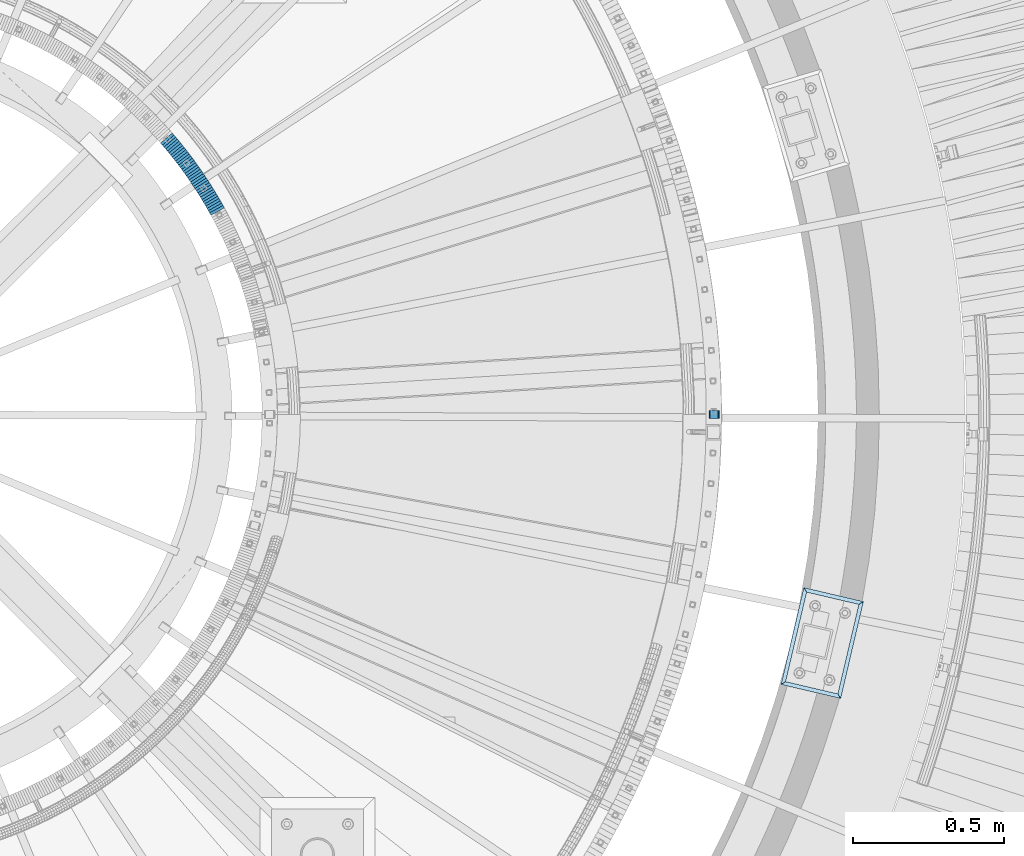
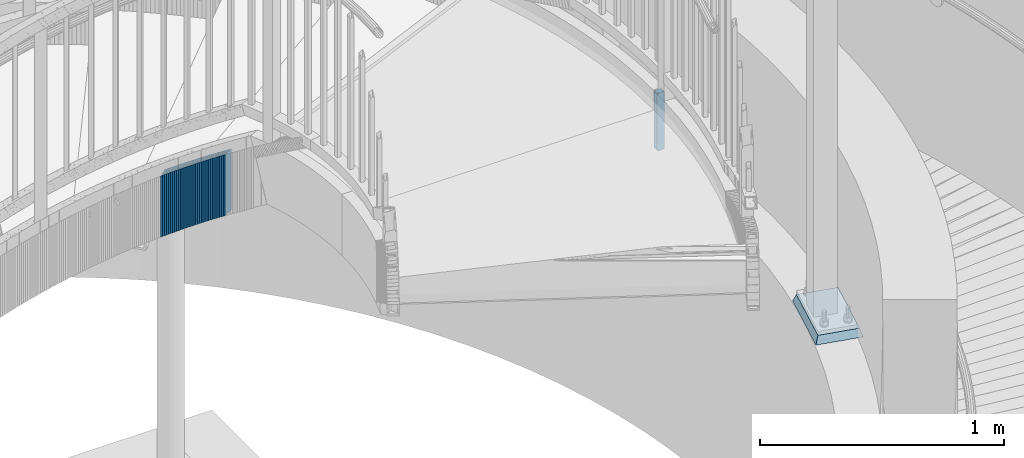
# One storey, part 910 of 975: 36 plates.
"""IFC2X3 building model written with IfcOpenShell, lengths in millimetres."""

from ifc_helpers import new_model, si_unit, frame, origin_with_axes, place, context, subcontext, project, spatial, faceted_brep, material, type_object, element, save


model = new_model("IFC2X3")

# Units and contexts
model_context = context("Model", 3, precision=1e-05, world=origin_with_axes())
body_context = subcontext(model_context, "Body", "Model", "MODEL_VIEW")
ifc_project = project(units=[si_unit("LENGTHUNIT", "METRE", prefix="MILLI"), si_unit("AREAUNIT", "SQUARE_METRE"), si_unit("VOLUMEUNIT", "CUBIC_METRE"), si_unit("MASSUNIT", "GRAM", prefix="KILO"), si_unit("TIMEUNIT", "SECOND"), si_unit("PLANEANGLEUNIT", "RADIAN"), si_unit("SOLIDANGLEUNIT", "STERADIAN"), si_unit("THERMODYNAMICTEMPERATUREUNIT", "DEGREE_CELSIUS"), si_unit("LUMINOUSINTENSITYUNIT", "LUMEN")], contexts=[model_context])

# Site, building, storey
site_placement = place(None, origin_with_axes())
site = spatial("IfcSite", under=ifc_project, at=site_placement, CompositionType="ELEMENT")
building_placement = place(site_placement, origin_with_axes())
building = spatial("IfcBuilding", under=site, at=building_placement, Name="Undefined", CompositionType="ELEMENT")
storey_placement = place(building_placement, origin_with_axes())
storey = spatial("IfcBuildingStorey", under=building, at=storey_placement, Name="Undefined", CompositionType="ELEMENT", Elevation=0.0)

# Plates
ifc_material_1 = material(Name="STEEL/A36")
plate_type_1 = type_object("IfcPlateType", PredefinedType="NOTDEFINED")
plate_1_placement = place(storey_placement, frame((37622.9779779098, 3403.59999999999, 2176.46249923706), z_axis=(0.0, 0.0, -1.0), x_axis=(-0.999999999999998, 6.90000001668524e-08, 0.0)))
element("IfcPlate", 1, at=plate_1_placement, inside=storey, type_object=plate_type_1, material=ifc_material_1, Name="PLATE", context=body_context, shape_type="Brep", body=[
    faceted_brep([(-4.05850369133987e-06, -12.7000000000298, 6.34999584616526), (0.0, -12.6999999999998, 282.574987888336), (0.0, 12.6999999999998, 282.574987888336), (-4.05842729378492e-06, 12.7000000000335, 6.34999584617253), (0.483364961291954, -12.6999999999998, 285.005027647359), (0.483364961291954, 12.6999999999998, 285.005027647359), (1.85987191153254, -12.6999999999998, 287.065115881436), (1.85987191153254, 12.6999999999998, 287.065115881436), (3.919960145613, -12.6999999999998, 288.441622831675), (3.919960145613, 12.6999999999998, 288.441622831675), (6.34999990463257, -12.6999999999998, 288.924987792969), (6.34999990463257, 12.6999999999998, 288.924987792969), (28.5687317848206, -12.6999999999998, 288.924987792969), (28.5687317848206, 12.6999999999998, 288.924987792969), (30.9987715438401, -12.6999999999998, 288.441622831675), (30.9987715438401, 12.6999999999998, 288.441622831675), (33.0588597779206, -12.6999999999998, 287.065115881436), (33.0588597779206, 12.6999999999998, 287.065115881436), (34.4353667281612, -12.6999999999998, 285.005027647359), (34.4353667281612, 12.6999999999998, 285.005027647359), (34.9187316894531, -12.6999999999998, 282.574987888336), (34.9187316894531, 12.6999999999998, 282.574987888336), (34.9187276514203, -12.6999999999643, 6.35000394271628), (34.9187276514895, 12.7000000000917, 6.35000394272356), (34.4353638491048, -12.6999999999607, 3.91996294363889), (34.4353638491739, 12.7000000000917, 3.91996294364617), (33.0588597779206, -12.6999999999998, 1.85987191153299), (33.0588597779206, 12.6999999999998, 1.85987191153299), (30.9987715438401, -12.6999999999998, 0.483364961293773), (30.9987715438401, 12.6999999999998, 0.483364961293773), (28.5687317848206, -12.6999999999998, 0.0), (28.5687317848206, 12.6999999999998, 0.0), (6.34999990463257, -12.6999999999998, 0.0), (6.34999990463257, 12.6999999999998, 0.0), (3.919960145613, -12.6999999999998, 0.483364961293773), (3.919960145613, 12.6999999999998, 0.483364961293773), (1.85987191153254, -12.6999999999998, 1.85987191153299), (1.85987191153254, 12.6999999999998, 1.85987191153299), (0.483362067625421, -12.7000000000262, 3.91995733345902), (0.483362067694543, 12.7000000000298, 3.91995733346448)], [[[0, 1, 2, 3]], [[1, 4, 5, 2]], [[4, 6, 7, 5]], [[6, 8, 9, 7]], [[8, 10, 11, 9]], [[10, 12, 13, 11]], [[12, 14, 15, 13]], [[14, 16, 17, 15]], [[16, 18, 19, 17]], [[18, 20, 21, 19]], [[20, 22, 23, 21]], [[22, 24, 25, 23]], [[24, 26, 27, 25]], [[26, 28, 29, 27]], [[28, 30, 31, 29]], [[30, 32, 33, 31]], [[32, 34, 35, 33]], [[34, 36, 37, 35]], [[36, 38, 39, 37]], [[38, 0, 3, 39]], [[5, 7, 9, 11, 13, 15, 17, 19, 21, 23, 25, 27, 29, 31, 33, 35, 37, 39, 3, 2]], [[38, 36, 34, 32, 30, 28, 26, 24, 22, 20, 18, 16, 14, 12, 10, 8, 6, 4, 1, 0]]]),
])
plate_type_2 = type_object("IfcPlateType", PredefinedType="NOTDEFINED")
plate_2_placement = place(storey_placement, frame((35954.131730669, 4084.69492811208, 2035.5000000012), z_axis=(0.482780508932904, -0.875741388878295, 0.0), x_axis=(0.0, 0.0, -1.0)))
element("IfcPlate", 2, at=plate_2_placement, inside=storey, type_object=plate_type_2, material=ifc_material_1, Name="WALL", context=body_context, shape_type="Brep", body=[
    faceted_brep([(0.0, -25.3999999999724, -1.81898940354586e-11), (-5.69999980926514, -25.400000000096, 8.9140338897214), (-5.69999980926514, 25.4000000000524, 8.91403388979779), (0.0, 25.3999999999869, 1.45519152283669e-11), (299.100006103516, -25.400000000096, 8.9140338897214), (299.100006103516, 25.4000000000524, 8.91403388979779), (304.799987792969, -25.3999999999724, -1.81898940354586e-11), (304.799987792969, 25.3999999999869, 1.45519152283669e-11)], [[[0, 1, 2, 3]], [[1, 4, 5, 2]], [[4, 6, 7, 5]], [[6, 0, 3, 7]], [[5, 7, 3, 2]], [[6, 4, 1, 0]]]),
])
plate_3_placement = place(storey_placement, frame((35949.8527088723, 4092.27799489274, 2029.8000000012), z_axis=(0.491321186669782, -0.870978467890795, 1.51524091052124e-10), x_axis=(0.0, 0.0, -1.0)))
element("IfcPlate", 3, at=plate_3_placement, inside=storey, type_object=plate_type_2, material=ifc_material_1, Name="WALL", context=body_context, shape_type="Brep", body=[
    faceted_brep([(0.0, -25.3999999999724, -1.81898940354586e-11), (-5.69999980926514, -25.4000000000087, 8.9643735885511), (-5.69999980926514, 25.4000000000669, 8.96437358860567), (0.0, 25.3999999999869, 1.45519152283669e-11), (299.100006103516, -25.4000000000087, 8.9643735885511), (299.100006103516, 25.4000000000669, 8.96437358860567), (304.799987792969, -25.3999999999724, -1.81898940354586e-11), (304.799987792969, 25.3999999999869, 1.45519152283669e-11)], [[[0, 1, 2, 3]], [[1, 4, 5, 2]], [[4, 6, 7, 5]], [[6, 0, 3, 7]], [[5, 7, 3, 2]], [[6, 4, 1, 0]]]),
])
for number, where, z_axis, x_axis, name in (
    (4, (35945.5221861386, 4099.8556240108, 2024.10000000119), (0.496138938141448, -0.868243142247537, 0.0), (0.0, 0.0, -1.0), "WALL"),
    (5, (35941.1221861366, 4107.5556240109, 2018.40000000118), (0.496138938141448, -0.868243142247537, 0.0), (0.0, 0.0, -1.0), "WALL"),
):
    element("IfcPlate", number, at=place(storey_placement, frame(where, z_axis=z_axis, x_axis=x_axis)), inside=storey, type_object=plate_type_2, material=ifc_material_1, Name=name, context=body_context, shape_type="Brep", body=[
        faceted_brep([(0.0, -25.3999999999724, -1.81898940354586e-11), (-5.69999980926514, -25.4000000000378, 8.86848354337781), (-5.69999980926514, 25.4000000000451, 8.86848354342146), (0.0, 25.3999999999869, 1.45519152283669e-11), (299.100006103516, -25.4000000000378, 8.86848354337781), (299.100006103516, 25.4000000000451, 8.86848354342146), (304.799987792969, -25.3999999999724, -1.81898940354586e-11), (304.799987792969, 25.3999999999869, 1.45519152283669e-11)], [[[0, 1, 2, 3]], [[1, 4, 5, 2]], [[4, 6, 7, 5]], [[6, 0, 3, 7]], [[5, 7, 3, 2]], [[6, 4, 1, 0]]]),
    ])
plate_4_placement = place(storey_placement, frame((35936.7459145663, 4115.04152535319, 2012.70000000118), z_axis=(0.504568019426507, -0.863371944049615, -2.19346475205384e-10), x_axis=(0.0, 0.0, -1.0)))
element("IfcPlate", 6, at=plate_4_placement, inside=storey, type_object=plate_type_2, material=ifc_material_1, Name="WALL", context=body_context, shape_type="Brep", body=[
    faceted_brep([(0.0, -25.3999999999724, -1.81898940354586e-11), (-5.69999980926514, -25.3999999999724, 8.91964149478372), (-5.69999980926514, 25.400000000016, 8.9196414947528), (0.0, 25.3999999999869, 1.45519152283669e-11), (299.100006103516, -25.3999999999724, 8.91964149478372), (299.100006103516, 25.400000000016, 8.9196414947528), (304.799987792969, -25.3999999999724, -1.81898940354586e-11), (304.799987792969, 25.3999999999869, 1.45519152283669e-11)], [[[0, 1, 2, 3]], [[1, 4, 5, 2]], [[4, 6, 7, 5]], [[6, 0, 3, 7]], [[5, 7, 3, 2]], [[6, 4, 1, 0]]]),
])
plate_5_placement = place(storey_placement, frame((35932.3194870752, 4122.51645606271, 2007.00000000118), z_axis=(0.509492006930814, -0.860475388883152, 0.0), x_axis=(0.0, 0.0, -1.0)))
element("IfcPlate", 7, at=plate_5_placement, inside=storey, type_object=plate_type_2, material=ifc_material_1, Name="WALL", context=body_context, shape_type="Brep", body=[
    faceted_brep([(0.0, -25.3999999999724, -1.81898940354586e-11), (-5.69999980926514, -25.4000000000742, 8.8323268889817), (-5.69999980926514, 25.4000000000815, 8.83232688909084), (0.0, 25.3999999999869, 1.45519152283669e-11), (299.100006103516, -25.4000000000742, 8.8323268889817), (299.100006103516, 25.4000000000815, 8.83232688909084), (304.799987792969, -25.3999999999724, -1.81898940354586e-11), (304.799987792969, 25.3999999999869, 1.45519152283669e-11)], [[[0, 1, 2, 3]], [[1, 4, 5, 2]], [[4, 6, 7, 5]], [[6, 0, 3, 7]], [[5, 7, 3, 2]], [[6, 4, 1, 0]]]),
])
plate_6_placement = place(storey_placement, frame((35927.7702945126, 4130.13102963732, 2001.30000000117), z_axis=(0.51285525212439, -0.858475095951204, -8.52323864819481e-11), x_axis=(0.0, 0.0, -1.0)))
element("IfcPlate", 8, at=plate_6_placement, inside=storey, type_object=plate_type_2, material=ifc_material_1, Name="WALL", context=body_context, shape_type="Brep", body=[
    faceted_brep([(0.0, -25.3999999999724, -1.81898940354586e-11), (-5.69999980926514, -25.4000000000669, 8.96939277644015), (-5.69999980926514, 25.4000000000524, 8.96939277652928), (0.0, 25.3999999999869, 1.45519152283669e-11), (299.100006103516, -25.4000000000669, 8.96939277644015), (299.100006103516, 25.4000000000524, 8.96939277652928), (304.799987792969, -25.3999999999724, -1.81898940354586e-11), (304.799987792969, 25.3999999999869, 1.45519152283669e-11)], [[[0, 1, 2, 3]], [[1, 4, 5, 2]], [[4, 6, 7, 5]], [[6, 0, 3, 7]], [[5, 7, 3, 2]], [[6, 4, 1, 0]]]),
])
plate_7_placement = place(storey_placement, frame((35923.3525425906, 4137.16979423657, 1995.60000000116), z_axis=(0.531014126038609, -0.847362967061609, 0.0), x_axis=(0.0, 0.0, -1.0)))
element("IfcPlate", 9, at=plate_7_placement, inside=storey, type_object=plate_type_2, material=ifc_material_1, Name="WALL", context=body_context, shape_type="Brep", body=[
    faceted_brep([(0.0, -25.3999999999724, -1.81898940354586e-11), (-5.69999980926514, -25.4000000000669, 8.85494232174278), (-5.69999980926514, 25.4000000000742, 8.85494232181918), (0.0, 25.3999999999869, 1.45519152283669e-11), (299.100006103516, -25.4000000000669, 8.85494232174278), (299.100006103516, 25.4000000000742, 8.85494232181918), (304.799987792969, -25.3999999999724, -1.81898940354586e-11), (304.799987792969, 25.3999999999869, 1.45519152283669e-11)], [[[0, 1, 2, 3]], [[1, 4, 5, 2]], [[4, 6, 7, 5]], [[6, 0, 3, 7]], [[5, 7, 3, 2]], [[6, 4, 1, 0]]]),
])
plate_8_placement = place(storey_placement, frame((35918.5458599453, 4145.10536498801, 1989.90000000115), z_axis=(0.517802678981105, -0.855500079275268, 1.01825207821094e-10), x_axis=(0.0, 0.0, -1.0)))
element("IfcPlate", 10, at=plate_8_placement, inside=storey, type_object=plate_type_2, material=ifc_material_1, Name="WALL", context=body_context, shape_type="Brep", body=[
    faceted_brep([(0.0, -25.3999999999724, -1.81898940354586e-11), (-5.69999980926514, -25.4000000000669, 8.8814411163039), (-5.69999980926514, 25.400000000096, 8.88144111637848), (0.0, 25.3999999999869, 1.45519152283669e-11), (299.100006103516, -25.4000000000669, 8.8814411163039), (299.100006103516, 25.400000000096, 8.88144111637848), (304.799987792969, -25.3999999999724, -1.81898940354586e-11), (304.799987792969, 25.3999999999869, 1.45519152283669e-11)], [[[0, 1, 2, 3]], [[1, 4, 5, 2]], [[4, 6, 7, 5]], [[6, 0, 3, 7]], [[5, 7, 3, 2]], [[6, 4, 1, 0]]]),
])
plate_9_placement = place(storey_placement, frame((35914.0818683767, 4152.06558915964, 1984.20000000114), z_axis=(0.539053696363117, -0.842271400700072, -2.99270595860435e-10), x_axis=(0.0, 0.0, -1.0)))
element("IfcPlate", 11, at=plate_9_placement, inside=storey, type_object=plate_type_2, material=ifc_material_1, Name="WALL", context=body_context, shape_type="Brep", body=[
    faceted_brep([(0.0, -25.3999999999724, -1.81898940354586e-11), (-5.69999980926514, -25.3999999999724, 8.90224647524519), (-5.69999980926514, 25.3999999999542, 8.90224647519426), (0.0, 25.3999999999869, 1.45519152283669e-11), (299.100006103516, -25.3999999999724, 8.90224647524519), (299.100006103516, 25.3999999999542, 8.90224647519426), (304.799987792969, -25.3999999999724, -1.81898940354586e-11), (304.799987792969, 25.3999999999869, 1.45519152283669e-11)], [[[0, 1, 2, 3]], [[1, 4, 5, 2]], [[4, 6, 7, 5]], [[6, 0, 3, 7]], [[5, 7, 3, 2]], [[6, 4, 1, 0]]]),
])
plate_10_placement = place(storey_placement, frame((35909.3346378059, 4159.53966878909, 1978.50000000114), z_axis=(0.536137175139273, -0.844130872219279, 0.0), x_axis=(0.0, 0.0, -1.0)))
element("IfcPlate", 12, at=plate_10_placement, inside=storey, type_object=plate_type_2, material=ifc_material_1, Name="WALL", context=body_context, shape_type="Brep", body=[
    faceted_brep([(0.0, -25.3999999999724, -1.81898940354586e-11), (-5.69999980926514, -25.399999999936, 8.76641273502901), (-5.69999980926514, 25.4000000000015, 8.76641273496898), (0.0, 25.3999999999869, 1.45519152283669e-11), (299.100006103516, -25.399999999936, 8.76641273502901), (299.100006103516, 25.4000000000015, 8.76641273496898), (304.799987792969, -25.3999999999724, -1.81898940354586e-11), (304.799987792969, 25.3999999999869, 1.45519152283669e-11)], [[[0, 1, 2, 3]], [[1, 4, 5, 2]], [[4, 6, 7, 5]], [[6, 0, 3, 7]], [[5, 7, 3, 2]], [[6, 4, 1, 0]]]),
])
plate_11_placement = place(storey_placement, frame((35904.5818683802, 4166.96558915965, 1972.80000000113), z_axis=(0.539053696363117, -0.842271400700072, -2.99270595860435e-10), x_axis=(0.0, 0.0, -1.0)))
element("IfcPlate", 13, at=plate_11_placement, inside=storey, type_object=plate_type_2, material=ifc_material_1, Name="WALL", context=body_context, shape_type="Brep", body=[
    faceted_brep([(0.0, -25.3999999999724, -1.81898940354586e-11), (-5.69999980926514, -25.3999999999724, 8.90224647524519), (-5.69999980926514, 25.3999999999542, 8.90224647519426), (0.0, 25.3999999999869, 1.45519152283669e-11), (299.100006103516, -25.3999999999724, 8.90224647524519), (299.100006103516, 25.3999999999542, 8.90224647519426), (304.799987792969, -25.3999999999724, -1.81898940354586e-11), (304.799987792969, 25.3999999999869, 1.45519152283669e-11)], [[[0, 1, 2, 3]], [[1, 4, 5, 2]], [[4, 6, 7, 5]], [[6, 0, 3, 7]], [[5, 7, 3, 2]], [[6, 4, 1, 0]]]),
])
plate_12_placement = place(storey_placement, frame((35899.8975585646, 4174.03428052, 1967.10000000112), z_axis=(0.552097343096909, -0.833779661388627, 8.59072315506636e-11), x_axis=(0.0, 0.0, -1.0)))
element("IfcPlate", 14, at=plate_12_placement, inside=storey, type_object=plate_type_2, material=ifc_material_1, Name="WALL", context=body_context, shape_type="Brep", body=[
    faceted_brep([(0.0, -25.3999999999724, -1.81898940354586e-11), (-5.69999980926514, -25.4000000000669, 8.8814411163039), (-5.69999980926514, 25.400000000096, 8.88144111637848), (0.0, 25.3999999999869, 1.45519152283669e-11), (299.100006103516, -25.4000000000669, 8.8814411163039), (299.100006103516, 25.400000000096, 8.88144111637848), (304.799987792969, -25.3999999999724, -1.81898940354586e-11), (304.799987792969, 25.3999999999869, 1.45519152283669e-11)], [[[0, 1, 2, 3]], [[1, 4, 5, 2]], [[4, 6, 7, 5]], [[6, 0, 3, 7]], [[5, 7, 3, 2]], [[6, 4, 1, 0]]]),
])
plate_13_placement = place(storey_placement, frame((35894.9975585624, 4181.43428052024, 1961.50000000111), z_axis=(0.552097343096909, -0.833779661388627, 8.59072315506636e-11), x_axis=(0.0, 0.0, -1.0)))
element("IfcPlate", 15, at=plate_13_placement, inside=storey, type_object=plate_type_2, material=ifc_material_1, Name="WALL", context=body_context, shape_type="Brep", body=[
    faceted_brep([(0.0, -25.3999999999724, -1.81898940354586e-11), (-5.59999990463257, -25.3999999999614, 8.87524604800456), (-5.59999990463257, 25.3999999999323, 8.87524604792998), (0.0, 25.3999999999869, 1.45519152283669e-11), (299.200012207031, -25.3999999999614, 8.87524604800456), (299.200012207031, 25.3999999999323, 8.87524604792998), (304.799987792969, -25.3999999999724, -1.81898940354586e-11), (304.799987792969, 25.3999999999869, 1.45519152283669e-11)], [[[0, 1, 2, 3]], [[1, 4, 5, 2]], [[4, 6, 7, 5]], [[6, 0, 3, 7]], [[5, 7, 3, 2]], [[6, 4, 1, 0]]]),
])
plate_14_placement = place(storey_placement, frame((35890.1860354407, 4188.60156946435, 1955.80000000111), z_axis=(0.557322187932383, -0.830296319899265, 0.0), x_axis=(0.0, 0.0, -1.0)))
element("IfcPlate", 16, at=plate_14_placement, inside=storey, type_object=plate_type_2, material=ifc_material_1, Name="WALL", context=body_context, shape_type="Brep", body=[
    faceted_brep([(0.0, -25.3999999999724, -1.81898940354586e-11), (-5.69999980926514, -25.4000000000669, 8.79204177851716), (-5.69999980926514, 25.4000000000487, 8.79204177860811), (0.0, 25.3999999999869, 1.45519152283669e-11), (299.100006103516, -25.4000000000669, 8.79204177851716), (299.100006103516, 25.4000000000487, 8.79204177860811), (304.799987792969, -25.3999999999724, -1.81898940354586e-11), (304.799987792969, 25.3999999999869, 1.45519152283669e-11)], [[[0, 1, 2, 3]], [[1, 4, 5, 2]], [[4, 6, 7, 5]], [[6, 0, 3, 7]], [[5, 7, 3, 2]], [[6, 4, 1, 0]]]),
])
plate_15_placement = place(storey_placement, frame((35885.2294021584, 4195.93717479967, 1950.1000000011), z_axis=(0.559857411630225, -0.828588968453421, -5.37864252692088e-10), x_axis=(0.0, 0.0, -1.0)))
element("IfcPlate", 17, at=plate_15_placement, inside=storey, type_object=plate_type_2, material=ifc_material_1, Name="WALL", context=body_context, shape_type="Brep", body=[
    faceted_brep([(0.0, -25.3999999999724, -1.81898940354586e-11), (-5.69999980926514, -25.3999999999141, 8.92748546604707), (-5.69999980926514, 25.3999999999505, 8.92748546598159), (0.0, 25.3999999999869, 1.45519152283669e-11), (299.100006103516, -25.3999999999141, 8.92748546604707), (299.100006103516, 25.3999999999505, 8.92748546598159), (304.799987792969, -25.3999999999724, -1.81898940354586e-11), (304.799987792969, 25.3999999999869, 1.45519152283669e-11)], [[[0, 1, 2, 3]], [[1, 4, 5, 2]], [[4, 6, 7, 5]], [[6, 0, 3, 7]], [[5, 7, 3, 2]], [[6, 4, 1, 0]]]),
])
plate_16_placement = place(storey_placement, frame((35880.2614034806, 4203.14374110295, 1944.30000000109), z_axis=(0.567472910754157, -0.823392066733828, 3.25858309224714e-11), x_axis=(0.0, 0.0, -1.0)))
element("IfcPlate", 18, at=plate_16_placement, inside=storey, type_object=plate_type_2, material=ifc_material_1, Name="WALL", context=body_context, shape_type="Brep", body=[
    faceted_brep([(0.0, -25.3999999999724, -1.81898940354586e-11), (-5.80000019073486, -25.3999999999796, 8.98721313478018), (-5.80000019073486, 25.399999999936, 8.98721313473106), (0.0, 25.3999999999869, 1.45519152283669e-11), (299.0, -25.3999999999796, 8.98721313478018), (299.0, 25.399999999936, 8.98721313473106), (304.799987792969, -25.3999999999724, -1.81898940354586e-11), (304.799987792969, 25.3999999999869, 1.45519152283669e-11)], [[[0, 1, 2, 3]], [[1, 4, 5, 2]], [[4, 6, 7, 5]], [[6, 0, 3, 7]], [[5, 7, 3, 2]], [[6, 4, 1, 0]]]),
])
plate_17_placement = place(storey_placement, frame((35875.2876007686, 4210.12092312949, 1938.60000000107), z_axis=(0.580182279890535, -0.814486661708478, -5.08648554387038e-11), x_axis=(0.0, 0.0, -1.0)))
element("IfcPlate", 19, at=plate_17_placement, inside=storey, type_object=plate_type_2, material=ifc_material_1, Name="WALL", context=body_context, shape_type="Brep", body=[
    faceted_brep([(0.0, -25.3999999999724, -1.81898940354586e-11), (-5.69999980926514, -25.4000000000087, 8.9643735885511), (-5.69999980926514, 25.4000000000669, 8.96437358860567), (0.0, 25.3999999999869, 1.45519152283669e-11), (299.100006103516, -25.4000000000087, 8.9643735885511), (299.100006103516, 25.4000000000669, 8.96437358860567), (304.799987792969, -25.3999999999724, -1.81898940354586e-11), (304.799987792969, 25.3999999999869, 1.45519152283669e-11)], [[[0, 1, 2, 3]], [[1, 4, 5, 2]], [[4, 6, 7, 5]], [[6, 0, 3, 7]], [[5, 7, 3, 2]], [[6, 4, 1, 0]]]),
])
plate_18_placement = place(storey_placement, frame((35870.0876007709, 4217.42092312917, 1932.80000000106), z_axis=(0.580182279890535, -0.814486661708478, -5.08648554387038e-11), x_axis=(0.0, 0.0, -1.0)))
element("IfcPlate", 20, at=plate_18_placement, inside=storey, type_object=plate_type_2, material=ifc_material_1, Name="WALL", context=body_context, shape_type="Brep", body=[
    faceted_brep([(0.0, -25.3999999999724, -1.81898940354586e-11), (-5.80000019073486, -25.3999999999396, 8.9627008438656), (-5.80000019073486, 25.3999999999178, 8.96270084374191), (0.0, 25.3999999999869, 1.45519152283669e-11), (299.0, -25.3999999999396, 8.9627008438656), (299.0, 25.3999999999178, 8.96270084374191), (304.799987792969, -25.3999999999724, -1.81898940354586e-11), (304.799987792969, 25.3999999999869, 1.45519152283669e-11)], [[[0, 1, 2, 3]], [[1, 4, 5, 2]], [[4, 6, 7, 5]], [[6, 0, 3, 7]], [[5, 7, 3, 2]], [[6, 4, 1, 0]]]),
])
plate_19_placement = place(storey_placement, frame((35864.8876007733, 4224.72092312899, 1927.10000000105), z_axis=(0.580182279890535, -0.814486661708478, -5.08648554387038e-11), x_axis=(0.0, 0.0, -1.0)))
element("IfcPlate", 21, at=plate_19_placement, inside=storey, type_object=plate_type_2, material=ifc_material_1, Name="WALL", context=body_context, shape_type="Brep", body=[
    faceted_brep([(0.0, -25.3999999999724, -1.81898940354586e-11), (-5.69999980926514, -25.4000000000087, 8.9643735885511), (-5.69999980926514, 25.4000000000669, 8.96437358860567), (0.0, 25.3999999999869, 1.45519152283669e-11), (299.100006103516, -25.4000000000087, 8.9643735885511), (299.100006103516, 25.4000000000669, 8.96437358860567), (304.799987792969, -25.3999999999724, -1.81898940354586e-11), (304.799987792969, 25.3999999999869, 1.45519152283669e-11)], [[[0, 1, 2, 3]], [[1, 4, 5, 2]], [[4, 6, 7, 5]], [[6, 0, 3, 7]], [[5, 7, 3, 2]], [[6, 4, 1, 0]]]),
])
plate_20_placement = place(storey_placement, frame((35859.820005127, 4231.59999036237, 1921.30000000105), z_axis=(0.592817428282397, -0.80533688399616, -1.4644820112153e-10), x_axis=(0.0, 0.0, -1.0)))
element("IfcPlate", 22, at=plate_20_placement, inside=storey, type_object=plate_type_2, material=ifc_material_1, Name="WALL", context=body_context, shape_type="Brep", body=[
    faceted_brep([(0.0, -25.3999999999724, -1.81898940354586e-11), (-5.80000019073486, -25.3999999999287, 8.93756103519445), (-5.80000019073486, 25.399999999936, 8.93756103512169), (0.0, 25.3999999999869, 1.45519152283669e-11), (299.0, -25.3999999999287, 8.93756103519445), (299.0, 25.399999999936, 8.93756103512169), (304.799987792969, -25.3999999999724, -1.81898940354586e-11), (304.799987792969, 25.3999999999869, 1.45519152283669e-11)], [[[0, 1, 2, 3]], [[1, 4, 5, 2]], [[4, 6, 7, 5]], [[6, 0, 3, 7]], [[5, 7, 3, 2]], [[6, 4, 1, 0]]]),
])
plate_21_placement = place(storey_placement, frame((35854.5200051289, 4238.79999036187, 1915.60000000105), z_axis=(0.592817428282397, -0.80533688399616, -1.4644820112153e-10), x_axis=(0.0, 0.0, -1.0)))
element("IfcPlate", 23, at=plate_21_placement, inside=storey, type_object=plate_type_2, material=ifc_material_1, Name="WALL", context=body_context, shape_type="Brep", body=[
    faceted_brep([(0.0, -25.3999999999724, -1.81898940354586e-11), (-5.69999980926514, -25.4000000000415, 8.93756103511259), (-5.69999980926514, 25.4000000000815, 8.93756103522537), (0.0, 25.3999999999869, 1.45519152283669e-11), (299.100006103516, -25.4000000000415, 8.93756103511259), (299.100006103516, 25.4000000000815, 8.93756103522537), (304.799987792969, -25.3999999999724, -1.81898940354586e-11), (304.799987792969, 25.3999999999869, 1.45519152283669e-11)], [[[0, 1, 2, 3]], [[1, 4, 5, 2]], [[4, 6, 7, 5]], [[6, 0, 3, 7]], [[5, 7, 3, 2]], [[6, 4, 1, 0]]]),
])
plate_22_placement = place(storey_placement, frame((35849.3212120366, 4245.7634608173, 1909.90000000104), z_axis=(0.598192607015844, -0.801352360021226, 0.0), x_axis=(0.0, 0.0, -1.0)))
element("IfcPlate", 24, at=plate_22_placement, inside=storey, type_object=plate_type_2, material=ifc_material_1, Name="WALL", context=body_context, shape_type="Brep", body=[
    faceted_brep([(0.0, -25.3999999999724, -1.81898940354586e-11), (-5.69999980926491, -25.3999999999869, 8.86002254486812), (-5.69999980926491, 25.3999999999942, 8.86002254485538), (0.0, 25.3999999999869, 1.45519152283669e-11), (299.100006103516, -25.3999999999869, 8.86002254486812), (299.100006103516, 25.3999999999942, 8.86002254485538), (304.799987792969, -25.3999999999724, -1.81898940354586e-11), (304.799987792969, 25.3999999999869, 1.45519152283669e-11)], [[[0, 1, 2, 3]], [[1, 4, 5, 2]], [[4, 6, 7, 5]], [[6, 0, 3, 7]], [[5, 7, 3, 2]], [[6, 4, 1, 0]]]),
])
plate_23_placement = place(storey_placement, frame((35844.0585305511, 4252.68121926655, 1904.10000000104), z_axis=(0.605367471185716, -0.795946119300931, 2.19515641219914e-11), x_axis=(0.0, 0.0, -1.0)))
element("IfcPlate", 25, at=plate_23_placement, inside=storey, type_object=plate_type_2, material=ifc_material_1, Name="WALL", context=body_context, shape_type="Brep", body=[
    faceted_brep([(0.0, -25.3999999999724, -1.81898940354586e-11), (-5.80000019073486, -25.3999999999724, 8.9196414947728), (-5.80000019073486, 25.4000000000342, 8.91964149478736), (0.0, 25.3999999999869, 1.45519152283669e-11), (299.0, -25.3999999999724, 8.9196414947728), (299.0, 25.4000000000342, 8.91964149478736), (304.799987792969, -25.3999999999724, -1.81898940354586e-11), (304.799987792969, 25.3999999999869, 1.45519152283669e-11)], [[[0, 1, 2, 3]], [[1, 4, 5, 2]], [[4, 6, 7, 5]], [[6, 0, 3, 7]], [[5, 7, 3, 2]], [[6, 4, 1, 0]]]),
])
for number, where, z_axis, x_axis, name in (
    (26, (35838.6955967565, 4259.60265038573, 1898.40000000104), (0.612397742071008, -0.790549812160076, 2.70556483883411e-11), (0.0, 0.0, -1.0), "WALL"),
    (27, (35833.1955967606, 4266.70265038549, 1892.70000000103), (0.612397742071008, -0.790549812160076, 2.70556483883411e-11), (0.0, 0.0, -1.0), "WALL"),
):
    element("IfcPlate", number, at=place(storey_placement, frame(where, z_axis=z_axis, x_axis=x_axis)), inside=storey, type_object=plate_type_2, material=ifc_material_1, Name=name, context=body_context, shape_type="Brep", body=[
        faceted_brep([(0.0, -25.3999999999724, -1.81898940354586e-11), (-5.69999980926514, -25.3999999999833, 8.98053455353147), (-5.69999980926514, 25.3999999999396, 8.98053455348781), (0.0, 25.3999999999869, 1.45519152283669e-11), (299.100006103516, -25.3999999999833, 8.98053455353147), (299.100006103516, 25.3999999999396, 8.98053455348781), (304.799987792969, -25.3999999999724, -1.81898940354586e-11), (304.799987792969, 25.3999999999869, 1.45519152283669e-11)], [[[0, 1, 2, 3]], [[1, 4, 5, 2]], [[4, 6, 7, 5]], [[6, 0, 3, 7]], [[5, 7, 3, 2]], [[6, 4, 1, 0]]]),
    ])
plate_24_placement = place(storey_placement, frame((35827.8030761884, 4273.56488561713, 1887.00000000103), z_axis=(0.617821551956281, -0.786318338803269, -5.58129613636994e-11), x_axis=(0.0, 0.0, -1.0)))
element("IfcPlate", 28, at=plate_24_placement, inside=storey, type_object=plate_type_2, material=ifc_material_1, Name="WALL", context=body_context, shape_type="Brep", body=[
    faceted_brep([(0.0, -25.3999999999724, -1.81898940354586e-11), (-5.69999980926514, -25.3999999999724, 8.90224647524519), (-5.69999980926514, 25.3999999999542, 8.90224647519426), (0.0, 25.3999999999869, 1.45519152283669e-11), (299.100006103516, -25.3999999999724, 8.90224647524519), (299.100006103516, 25.3999999999542, 8.90224647519426), (304.799987792969, -25.3999999999724, -1.81898940354586e-11), (304.799987792969, 25.3999999999869, 1.45519152283669e-11)], [[[0, 1, 2, 3]], [[1, 4, 5, 2]], [[4, 6, 7, 5]], [[6, 0, 3, 7]], [[5, 7, 3, 2]], [[6, 4, 1, 0]]]),
])
plate_25_placement = place(storey_placement, frame((35822.4535264025, 4280.15126327293, 1881.20000000101), z_axis=(0.630168888016676, -0.776458094539445, 2.13421117223333e-10), x_axis=(0.0, 0.0, -1.0)))
element("IfcPlate", 29, at=plate_25_placement, inside=storey, type_object=plate_type_2, material=ifc_material_1, Name="WALL", context=body_context, shape_type="Brep", body=[
    faceted_brep([(0.0, -25.3999999999724, -1.81898940354586e-11), (-5.80000019073486, -25.3999999999542, 8.88650703432359), (-5.80000019073486, 25.4000000000233, 8.88650703432359), (0.0, 25.3999999999869, 1.45519152283669e-11), (299.0, -25.3999999999542, 8.88650703432359), (299.0, 25.4000000000233, 8.88650703432359), (304.799987792969, -25.3999999999724, -1.81898940354586e-11), (304.799987792969, 25.3999999999869, 1.45519152283669e-11)], [[[0, 1, 2, 3]], [[1, 4, 5, 2]], [[4, 6, 7, 5]], [[6, 0, 3, 7]], [[5, 7, 3, 2]], [[6, 4, 1, 0]]]),
])
plate_26_placement = place(storey_placement, frame((35816.7414942518, 4287.29029881472, 1875.50000000102), z_axis=(0.624695048042231, -0.780868809052785, 0.0), x_axis=(0.0, 0.0, -1.0)))
element("IfcPlate", 30, at=plate_26_placement, inside=storey, type_object=plate_type_2, material=ifc_material_1, Name="WALL", context=body_context, shape_type="Brep", body=[
    faceted_brep([(0.0, -25.3999999999724, -1.81898940354586e-11), (-5.69999980926514, -25.4000000000087, 8.9643735885511), (-5.69999980926514, 25.4000000000669, 8.96437358860567), (0.0, 25.3999999999869, 1.45519152283669e-11), (299.100006103516, -25.4000000000087, 8.9643735885511), (299.100006103516, 25.4000000000669, 8.96437358860567), (304.799987792969, -25.3999999999724, -1.81898940354586e-11), (304.799987792969, 25.3999999999869, 1.45519152283669e-11)], [[[0, 1, 2, 3]], [[1, 4, 5, 2]], [[4, 6, 7, 5]], [[6, 0, 3, 7]], [[5, 7, 3, 2]], [[6, 4, 1, 0]]]),
])
plate_27_placement = place(storey_placement, frame((35811.2931334989, 4293.88076428571, 1869.800000001), z_axis=(0.636881446815393, -0.770961751776527, 0.0), x_axis=(0.0, 0.0, -1.0)))
element("IfcPlate", 31, at=plate_27_placement, inside=storey, type_object=plate_type_2, material=ifc_material_1, Name="WALL", context=body_context, shape_type="Brep", body=[
    faceted_brep([(0.0, -25.3999999999724, -1.81898940354586e-11), (-5.69999980926514, -25.4000000000451, 8.94986057279493), (-5.69999980926514, 25.3999999999942, 8.94986057280948), (0.0, 25.3999999999869, 1.45519152283669e-11), (299.100006103516, -25.4000000000451, 8.94986057279493), (299.100006103516, 25.3999999999942, 8.94986057280948), (304.799987792969, -25.3999999999724, -1.81898940354586e-11), (304.799987792969, 25.3999999999869, 1.45519152283669e-11)], [[[0, 1, 2, 3]], [[1, 4, 5, 2]], [[4, 6, 7, 5]], [[6, 0, 3, 7]], [[5, 7, 3, 2]], [[6, 4, 1, 0]]]),
])
plate_28_placement = place(storey_placement, frame((35805.5931334913, 4300.78076428562, 1864.00000000099), z_axis=(0.636881446815393, -0.770961751776527, 0.0), x_axis=(0.0, 0.0, -1.0)))
element("IfcPlate", 32, at=plate_28_placement, inside=storey, type_object=plate_type_2, material=ifc_material_1, Name="WALL", context=body_context, shape_type="Brep", body=[
    faceted_brep([(0.0, -25.3999999999724, -1.81898940354586e-11), (-5.80000019073486, -25.4000000000742, 8.94706630702785), (-5.80000019073486, 25.4000000000306, 8.9470663070897), (0.0, 25.3999999999869, 1.45519152283669e-11), (299.0, -25.4000000000742, 8.94706630702785), (299.0, 25.4000000000306, 8.9470663070897), (304.799987792969, -25.3999999999724, -1.81898940354586e-11), (304.799987792969, 25.3999999999869, 1.45519152283669e-11)], [[[0, 1, 2, 3]], [[1, 4, 5, 2]], [[4, 6, 7, 5]], [[6, 0, 3, 7]], [[5, 7, 3, 2]], [[6, 4, 1, 0]]]),
])
for number, where, z_axis, x_axis, name in (
    (33, (35800.0503795998, 4307.27430924156, 1858.30000000099), (0.648946606019702, -0.760833952012862, -4.31282387580723e-12), (0.0, 0.0, -1.0), "WALL"),
    (34, (35794.2503795944, 4314.07430924206, 1852.60000000099), (0.648946606019702, -0.760833952012862, -4.31282387580723e-12), (0.0, 0.0, -1.0), "WALL"),
):
    element("IfcPlate", number, at=place(storey_placement, frame(where, z_axis=z_axis, x_axis=x_axis)), inside=storey, type_object=plate_type_2, material=ifc_material_1, Name=name, context=body_context, shape_type="Brep", body=[
        faceted_brep([(0.0, -25.3999999999724, -1.81898940354586e-11), (-5.69999980926514, -25.4000000000415, 8.93756103511259), (-5.69999980926514, 25.4000000000815, 8.93756103522537), (0.0, 25.3999999999869, 1.45519152283669e-11), (299.100006103516, -25.4000000000415, 8.93756103511259), (299.100006103516, 25.4000000000815, 8.93756103522537), (304.799987792969, -25.3999999999724, -1.81898940354586e-11), (304.799987792969, 25.3999999999869, 1.45519152283669e-11)], [[[0, 1, 2, 3]], [[1, 4, 5, 2]], [[4, 6, 7, 5]], [[6, 0, 3, 7]], [[5, 7, 3, 2]], [[6, 4, 1, 0]]]),
    ])
plate_29_placement = place(storey_placement, frame((35788.5716051681, 4320.63323221177, 1846.80000000099), z_axis=(0.654500819759056, -0.756061291784418, 2.68819349003024e-11), x_axis=(0.0, 0.0, -1.0)))
element("IfcPlate", 35, at=plate_29_placement, inside=storey, type_object=plate_type_2, material=ifc_material_1, Name="WALL", context=body_context, shape_type="Brep", body=[
    faceted_brep([(0.0, -25.3999999999724, -1.81898940354586e-11), (-5.80000019073486, -25.3999999999905, 8.8617153167761), (-5.80000019073486, 25.4000000000524, 8.86171531681975), (0.0, 25.3999999999869, 1.45519152283669e-11), (299.0, -25.3999999999905, 8.8617153167761), (299.0, 25.4000000000524, 8.86171531681975), (304.799987792969, -25.3999999999724, -1.81898940354586e-11), (304.799987792969, 25.3999999999869, 1.45519152283669e-11)], [[[0, 1, 2, 3]], [[1, 4, 5, 2]], [[4, 6, 7, 5]], [[6, 0, 3, 7]], [[5, 7, 3, 2]], [[6, 4, 1, 0]]]),
])
ifc_material_2 = material(Name="CONCRETE/GROUT")
plate_type_3 = type_object("IfcPlateType", PredefinedType="NOTDEFINED")
plate_30_placement = place(storey_placement, frame((37903.3585621883, 2829.35885100266, 1390.65), z_axis=(0.973539033329667, -0.228520788077446, 0.0), x_axis=(-0.228520788077446, -0.973539033329667, 0.0)))
element("IfcPlate", 36, at=plate_30_placement, inside=storey, type_object=plate_type_3, material=ifc_material_2, Name="GROUT", context=body_context, shape_type="Brep", body=[
    faceted_brep([(330.200012367033, 19.0500013667977, 203.199997417756), (1.09139364212751e-11, 19.05, 203.199996948282), (12.7000000020234, -19.0499999844749, 190.500000003405), (317.500000003602, -19.049999999379, 190.499999996773), (330.200012206657, 19.0500004884277, -1.48389517562464e-07), (317.499999999585, -19.0499999999586, 12.6999999966938), (12.6999999980108, -19.0499999989649, 12.7000000033258), (2.63382389675826e-07, 19.0500000000138, 0.0)], [[[0, 1, 2, 3]], [[4, 5, 6, 7]], [[5, 4, 0, 3]], [[6, 5, 3, 2]], [[7, 6, 2, 1]], [[4, 7, 1, 0]]]),
])

save(model, "model.ifc")
